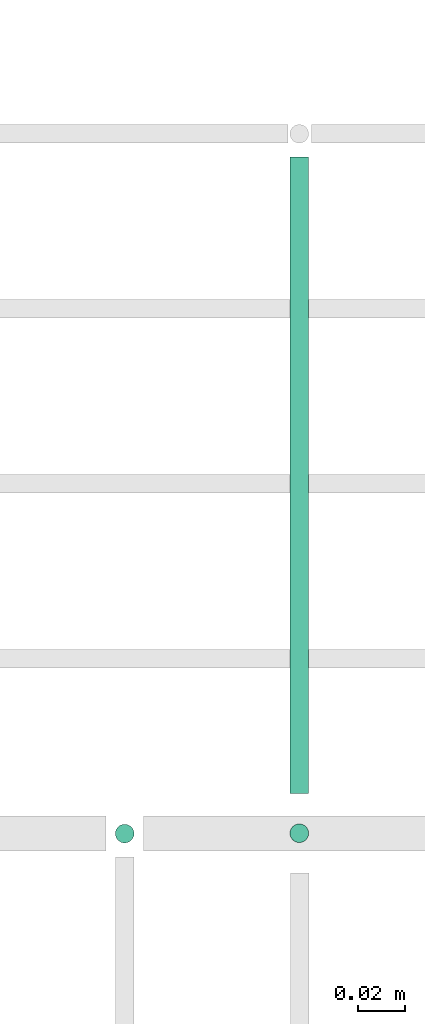
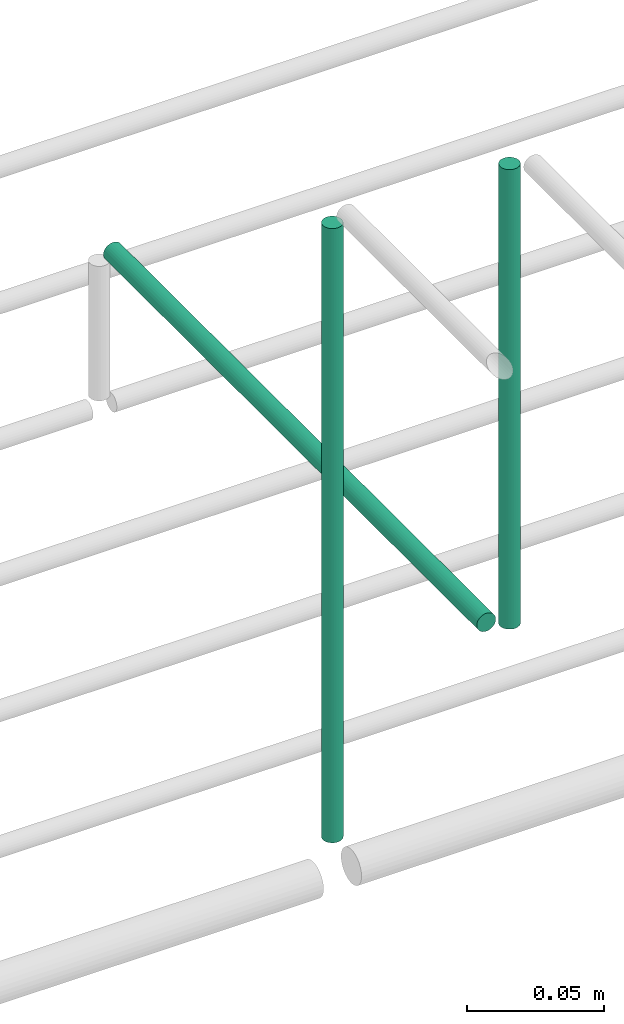
# One storey, part 63 of 89: 3 flow segments.
"""IFC2X3 building model written with IfcOpenShell, lengths in millimetres."""

from ifc_helpers import new_model, entity, si_unit, converted_unit, derived_unit, direction, frame, origin, origin_2d_with_axis, place, context, subcontext, project, spatial, circle, extrude, type_object, element, save


model = new_model("IFC2X3")

# Units and contexts
model_context = context("Model", 3, precision=0.01, world=origin(), true_north=direction((6.12303176911189e-17, 1.0)))
body_context = subcontext(model_context, "Body", "Model", "MODEL_VIEW")
ifc_project = project(units=[si_unit("LENGTHUNIT", "METRE", prefix="MILLI"), si_unit("AREAUNIT", "SQUARE_METRE"), si_unit("VOLUMEUNIT", "CUBIC_METRE"), converted_unit("PLANEANGLEUNIT", "DEGREE", entity("IfcRatioMeasure", 0.0174532925199433), si_unit("PLANEANGLEUNIT", "RADIAN"), dimensions=[0, 0, 0, 0, 0, 0, 0]), si_unit("MASSUNIT", "GRAM", prefix="KILO"), derived_unit("MASSDENSITYUNIT", [(si_unit("MASSUNIT", "GRAM", prefix="KILO"), 1), (si_unit("LENGTHUNIT", "METRE"), -3)]), derived_unit("MOMENTOFINERTIAUNIT", [(si_unit("LENGTHUNIT", "METRE"), 4)]), si_unit("TIMEUNIT", "SECOND"), si_unit("FREQUENCYUNIT", "HERTZ"), si_unit("THERMODYNAMICTEMPERATUREUNIT", "DEGREE_CELSIUS"), derived_unit("THERMALTRANSMITTANCEUNIT", [(si_unit("MASSUNIT", "GRAM", prefix="KILO"), 1), (si_unit("THERMODYNAMICTEMPERATUREUNIT", "KELVIN"), -1), (si_unit("TIMEUNIT", "SECOND"), -3)]), derived_unit("VOLUMETRICFLOWRATEUNIT", [(si_unit("LENGTHUNIT", "METRE"), 3), (si_unit("TIMEUNIT", "SECOND"), -1)]), derived_unit("MASSFLOWRATEUNIT", [(si_unit("MASSUNIT", "GRAM", prefix="KILO"), 1), (si_unit("TIMEUNIT", "SECOND"), -1)]), derived_unit("ROTATIONALFREQUENCYUNIT", [(si_unit("TIMEUNIT", "SECOND"), -1)]), si_unit("ELECTRICCURRENTUNIT", "AMPERE"), si_unit("ELECTRICVOLTAGEUNIT", "VOLT"), si_unit("POWERUNIT", "WATT"), si_unit("FORCEUNIT", "NEWTON", prefix="KILO"), si_unit("ILLUMINANCEUNIT", "LUX"), si_unit("LUMINOUSFLUXUNIT", "LUMEN"), si_unit("LUMINOUSINTENSITYUNIT", "CANDELA"), derived_unit("USERDEFINED", [(si_unit("MASSUNIT", "GRAM", prefix="KILO"), -1), (si_unit("LENGTHUNIT", "METRE"), -2), (si_unit("TIMEUNIT", "SECOND"), 3), (si_unit("LUMINOUSFLUXUNIT", "LUMEN"), 1)]), derived_unit("LINEARVELOCITYUNIT", [(si_unit("LENGTHUNIT", "METRE"), 1), (si_unit("TIMEUNIT", "SECOND"), -1)]), si_unit("PRESSUREUNIT", "PASCAL"), derived_unit("USERDEFINED", [(si_unit("LENGTHUNIT", "METRE"), -2), (si_unit("MASSUNIT", "GRAM", prefix="KILO"), 1), (si_unit("TIMEUNIT", "SECOND"), -2)]), derived_unit("LINEARFORCEUNIT", [(si_unit("MASSUNIT", "GRAM", prefix="KILO"), 1), (si_unit("LENGTHUNIT", "METRE"), 1), (si_unit("TIMEUNIT", "SECOND"), -2), (si_unit("LENGTHUNIT", "METRE"), -1)]), derived_unit("PLANARFORCEUNIT", [(si_unit("MASSUNIT", "GRAM", prefix="KILO"), 1), (si_unit("LENGTHUNIT", "METRE"), 1), (si_unit("TIMEUNIT", "SECOND"), -2), (si_unit("LENGTHUNIT", "METRE"), -2)])], contexts=[model_context])

# Site, building, storey
site_placement = place(None, frame((0.0, -0.00077364408347762, 0.0)))
site = spatial("IfcSite", under=ifc_project, at=site_placement, CompositionType="ELEMENT")
building_placement = place(site_placement, origin())
building = spatial("IfcBuilding", under=site, at=building_placement, CompositionType="ELEMENT")
storey_placement = place(building_placement, frame((0.0, 0.0, 24000.0)))
storey = spatial("IfcBuildingStorey", under=building, at=storey_placement, CompositionType="ELEMENT", Elevation=24000.0)

# Flow segments
pipe_segment_type = type_object("IfcPipeSegmentType", PredefinedType="NOTDEFINED")
flow_segment_1_placement = place(storey_placement, frame((55614.4556880888, 18644.4047277641, 2791.0)))
element("IfcFlowSegment", 1, at=flow_segment_1_placement, inside=storey, type_object=pipe_segment_type, context=body_context, shape_type="SweptSolid", body=[
    extrude(circle(Radius=4.0, at=origin_2d_with_axis()), frame((5.59527223591499, 5.59527223591499, 0.0), z_axis=(0.0, 0.0, 1.0), x_axis=(-1.0, 0.0, 0.0)), (0.0, 0.0, 1.0), 273.99999999999),
])
flow_segment_2_placement = place(storey_placement, frame((55689.3013260119, 18644.5582806598, 2859.99965095085)))
element("IfcFlowSegment", 2, at=flow_segment_2_placement, inside=storey, type_object=pipe_segment_type, context=body_context, shape_type="SweptSolid", body=[
    extrude(circle(Radius=4.0, at=origin_2d_with_axis()), frame((5.59527222064223, 5.59527223591499, 0.000349592837017099), z_axis=(8.73982106718787e-05, 0.0, 0.999999996180776), x_axis=(0.999999996180776, 0.0, -8.73982106718787e-05)), (0.0, 0.0, 1.0), 205.000000850331),
])
flow_segment_3_placement = place(storey_placement, frame((55689.3018114097, 18667.1535528393, 2844.40473042311)))
element("IfcFlowSegment", 3, at=flow_segment_3_placement, inside=storey, type_object=pipe_segment_type, context=body_context, shape_type="SweptSolid", body=[
    extrude(circle(Radius=4.0, at=origin_2d_with_axis()), frame((5.59527223591499, 0.0, 5.59527223591499), z_axis=(0.0, 1.0, 0.0), x_axis=(-1.0, 0.0, 0.0)), (0.0, 0.0, 1.0), 272.84644716076),
])

save(model, "model.ifc")
